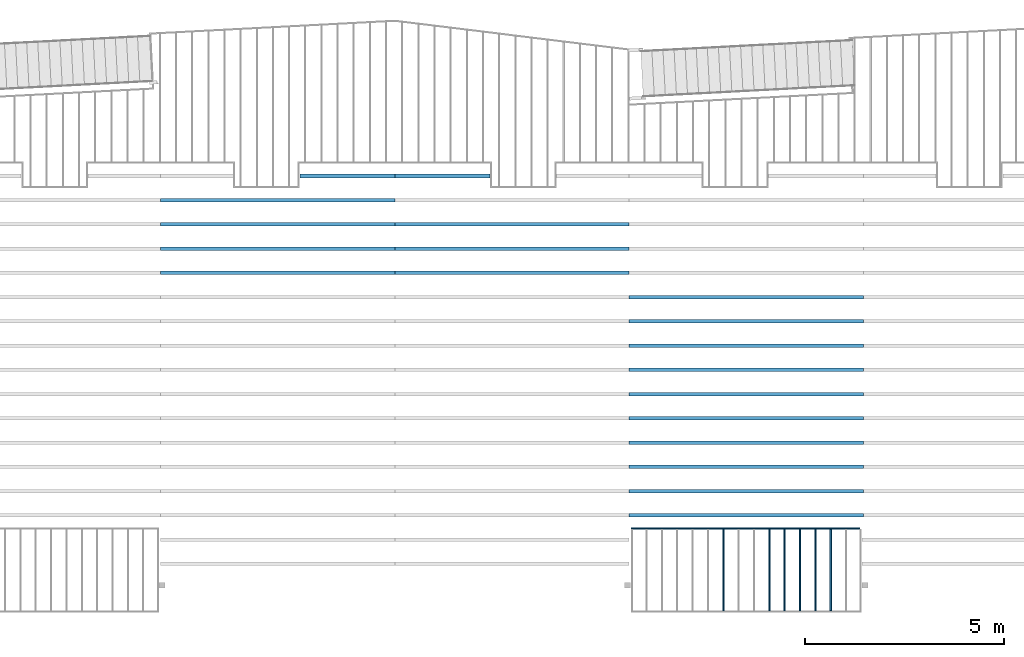
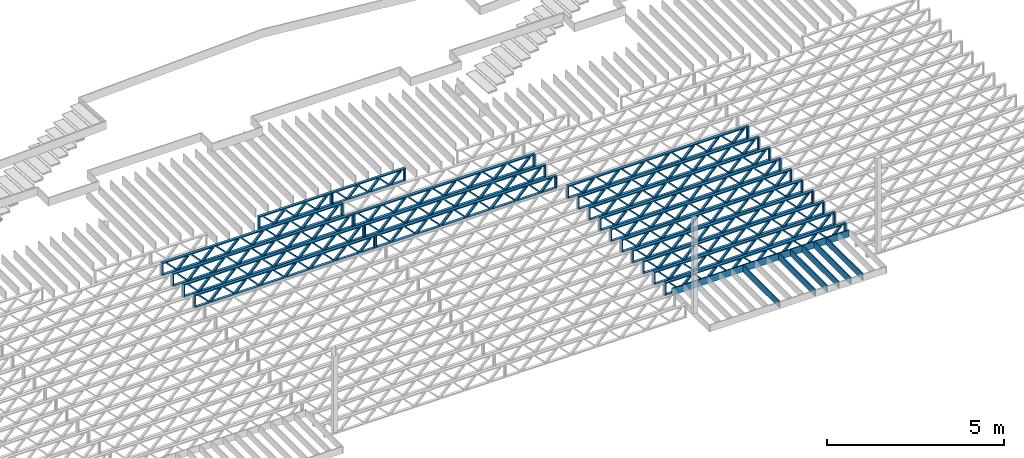
# One storey, part 7 of 23: 26 beams, 4 elements without a shape of their own.
"""IFC4 building model written with IfcOpenShell, lengths in feet."""

from ifc_helpers import new_model, entity, si_unit, converted_unit, derived_unit, direction, frame, frame_2d, origin, origin_2d_with_axis, place, context, subcontext, project, spatial, rectangle, extrude, source, transform, mapped, material, material_profile, profile_set, profile_usage, type_object, type_shapes, element, aggregate, save


model = new_model("IFC4")

# Units and contexts
model_context = context("Model", 3, precision=0.0001, world=origin(), true_north=direction((6.12303176911189e-17, 1.0)))
body_context = subcontext(model_context, "Body", "Model", "MODEL_VIEW")
ifc_project = project(units=[converted_unit("LENGTHUNIT", "FOOT", entity("IfcRatioMeasure", 0.3048), si_unit("LENGTHUNIT", "METRE"), dimensions=[1, 0, 0, 0, 0, 0, 0]), converted_unit("AREAUNIT", "SQUARE FOOT", entity("IfcRatioMeasure", 0.09290304), si_unit("AREAUNIT", "SQUARE_METRE"), dimensions=[2, 0, 0, 0, 0, 0, 0]), converted_unit("VOLUMEUNIT", "CUBIC FOOT", entity("IfcRatioMeasure", 0.028316846592), si_unit("VOLUMEUNIT", "CUBIC_METRE"), dimensions=[3, 0, 0, 0, 0, 0, 0]), converted_unit("PLANEANGLEUNIT", "DEGREE", entity("IfcRatioMeasure", 0.0174532925199433), si_unit("PLANEANGLEUNIT", "RADIAN"), dimensions=[0, 0, 0, 0, 0, 0, 0]), si_unit("MASSUNIT", "GRAM", prefix="KILO"), derived_unit("MASSDENSITYUNIT", [(si_unit("MASSUNIT", "GRAM", prefix="KILO"), 1), (si_unit("LENGTHUNIT", "METRE"), -3)]), derived_unit("MOMENTOFINERTIAUNIT", [(si_unit("LENGTHUNIT", "METRE"), 4)]), si_unit("TIMEUNIT", "SECOND"), si_unit("FREQUENCYUNIT", "HERTZ"), si_unit("THERMODYNAMICTEMPERATUREUNIT", "DEGREE_CELSIUS"), derived_unit("THERMALTRANSMITTANCEUNIT", [(si_unit("MASSUNIT", "GRAM", prefix="KILO"), 1), (si_unit("THERMODYNAMICTEMPERATUREUNIT", "KELVIN"), -1), (si_unit("TIMEUNIT", "SECOND"), -3)]), derived_unit("VOLUMETRICFLOWRATEUNIT", [(si_unit("LENGTHUNIT", "METRE"), 3), (si_unit("TIMEUNIT", "SECOND"), -1)]), si_unit("ELECTRICCURRENTUNIT", "AMPERE"), si_unit("ELECTRICVOLTAGEUNIT", "VOLT"), si_unit("POWERUNIT", "WATT"), si_unit("FORCEUNIT", "NEWTON"), si_unit("ILLUMINANCEUNIT", "LUX"), si_unit("LUMINOUSFLUXUNIT", "LUMEN"), si_unit("LUMINOUSINTENSITYUNIT", "CANDELA"), derived_unit("USERDEFINED", [(si_unit("MASSUNIT", "GRAM", prefix="KILO"), -1), (si_unit("LENGTHUNIT", "METRE"), -2), (si_unit("TIMEUNIT", "SECOND"), 3), (si_unit("LUMINOUSFLUXUNIT", "LUMEN"), 1)]), derived_unit("LINEARVELOCITYUNIT", [(si_unit("LENGTHUNIT", "METRE"), 1), (si_unit("TIMEUNIT", "SECOND"), -1)]), si_unit("PRESSUREUNIT", "PASCAL"), derived_unit("USERDEFINED", [(si_unit("LENGTHUNIT", "METRE"), -2), (si_unit("MASSUNIT", "GRAM", prefix="KILO"), 1), (si_unit("TIMEUNIT", "SECOND"), -2)]), derived_unit("LINEARFORCEUNIT", [(si_unit("MASSUNIT", "GRAM", prefix="KILO"), 1), (si_unit("LENGTHUNIT", "METRE"), 1), (si_unit("TIMEUNIT", "SECOND"), -2), (si_unit("LENGTHUNIT", "METRE"), -1)]), derived_unit("PLANARFORCEUNIT", [(si_unit("MASSUNIT", "GRAM", prefix="KILO"), 1), (si_unit("LENGTHUNIT", "METRE"), 1), (si_unit("TIMEUNIT", "SECOND"), -2), (si_unit("LENGTHUNIT", "METRE"), -2)])], contexts=[model_context])

# Site, building, storey
site_placement = place(None, origin())
site = spatial("IfcSite", under=ifc_project, at=site_placement, CompositionType="ELEMENT")
building_placement = place(site_placement, origin())
building = spatial("IfcBuilding", under=site, at=building_placement, CompositionType="ELEMENT")
storey_placement = place(building_placement, frame((0.0, 0.0, 10.8020833333333)))
storey = spatial("IfcBuildingStorey", under=building, at=storey_placement, Name="2ND FLOOR", CompositionType="ELEMENT", Elevation=10.8020833333333)

# Assembly, beams
assembly_1_placement = place(storey_placement, origin())
assembly_1 = element("IfcElementAssembly", 1, at=assembly_1_placement, inside=storey, Name="Structural Beam System:Structural Framing System", ObjectType="Structural Beam System:Structural Framing System", AssemblyPlace="NOTDEFINED", PredefinedType="BEAM_GRID")
ifc_material_1 = material(Category="Materials")
ifc_material_profile_1 = material_profile(ifc_material_1, rectangle(XDim=0.770833333333333, YDim=0.124999999999994, at=frame_2d((-5.55111512312578e-17, 0.0), x_axis=(1.0, 0.0))))
ifc_profile_set_1 = profile_set([ifc_material_profile_1])
ifc_profile_usage_1 = profile_usage(ifc_profile_set_1, cardinal=8)
beam_type_1 = type_object("IfcBeamType", PredefinedType="BEAM", material=ifc_profile_set_1)
shared_shape_1 = source(origin(), body_context, "Body", "SweptSolid", [
    extrude(rectangle(XDim=0.770833333333333, YDim=0.124999999999994, at=frame_2d((-5.55111512312578e-17, 0.0), x_axis=(1.0, 0.0))), frame((-3.35416666666737, 0.0, 0.0), z_axis=(1.0, 0.0, 0.0), x_axis=(0.0, 0.0, -1.0)), (0.0, 0.0, 1.0), 6.70833333333462),
])
type_shapes(beam_type_1, [shared_shape_1])
beam_1_placement = place(assembly_1_placement, frame((-167.102006703188, 925.341101549316, -0.645833333333471), z_axis=(0.0, 0.0, 1.0), x_axis=(0.0, 1.0, 0.0)))
beam_1 = element("IfcBeam", 2, at=beam_1_placement, type_object=beam_type_1, material=ifc_profile_usage_1, PredefinedType="BEAM", context=body_context, shape_type="MappedRepresentation", body=[
    mapped(shared_shape_1, transform((0.0, 0.0, 0.0), scale=1.0)),
])
ifc_profile_usage_2 = profile_usage(ifc_profile_set_1, cardinal=8)
beam_2_placement = place(assembly_1_placement, frame((-168.368890383746, 925.341101549316, -0.645833333333471), z_axis=(0.0, 0.0, 1.0), x_axis=(0.0, 1.0, 0.0)))
beam_2 = element("IfcBeam", 3, at=beam_2_placement, type_object=beam_type_1, material=ifc_profile_usage_2, PredefinedType="BEAM", context=body_context, shape_type="MappedRepresentation", body=[
    mapped(shared_shape_1, transform((0.0, 0.0, 0.0), scale=1.0)),
])
ifc_profile_usage_3 = profile_usage(ifc_profile_set_1, cardinal=8)
beam_3_placement = place(assembly_1_placement, frame((-169.635774064305, 925.341101549317, -0.645833333333471), z_axis=(0.0, 0.0, 1.0), x_axis=(0.0, 1.0, 0.0)))
beam_3 = element("IfcBeam", 4, at=beam_3_placement, type_object=beam_type_1, material=ifc_profile_usage_3, PredefinedType="BEAM", context=body_context, shape_type="MappedRepresentation", body=[
    mapped(shared_shape_1, transform((0.0, 0.0, 0.0), scale=1.0)),
])
ifc_profile_usage_4 = profile_usage(ifc_profile_set_1, cardinal=8)
beam_4_placement = place(assembly_1_placement, frame((-170.902657744863, 925.341101549317, -0.645833333333471), z_axis=(0.0, 0.0, 1.0), x_axis=(0.0, 1.0, 0.0)))
beam_4 = element("IfcBeam", 5, at=beam_4_placement, type_object=beam_type_1, material=ifc_profile_usage_4, PredefinedType="BEAM", context=body_context, shape_type="MappedRepresentation", body=[
    mapped(shared_shape_1, transform((0.0, 0.0, 0.0), scale=1.0)),
])
ifc_profile_usage_5 = profile_usage(ifc_profile_set_1, cardinal=8)
beam_5_placement = place(assembly_1_placement, frame((-172.169541425421, 925.341101549317, -0.645833333333471), z_axis=(0.0, 0.0, 1.0), x_axis=(0.0, 1.0, 0.0)))
beam_5 = element("IfcBeam", 6, at=beam_5_placement, type_object=beam_type_1, material=ifc_profile_usage_5, PredefinedType="BEAM", context=body_context, shape_type="MappedRepresentation", body=[
    mapped(shared_shape_1, transform((0.0, 0.0, 0.0), scale=1.0)),
])
ifc_profile_usage_6 = profile_usage(ifc_profile_set_1, cardinal=8)
beam_6_placement = place(assembly_1_placement, frame((-175.970192467096, 925.341101549318, -0.645833333333471), z_axis=(0.0, 0.0, 1.0), x_axis=(0.0, 1.0, 0.0)))
beam_6 = element("IfcBeam", 7, at=beam_6_placement, type_object=beam_type_1, material=ifc_profile_usage_6, PredefinedType="BEAM", context=body_context, shape_type="MappedRepresentation", body=[
    mapped(shared_shape_1, transform((0.0, 0.0, 0.0), scale=1.0)),
])
aggregate(assembly_1, [beam_1, beam_2, beam_3, beam_4, beam_5, beam_6])

assembly_2_placement = place(storey_placement, origin())
assembly_2 = element("IfcElementAssembly", 8, at=assembly_2_placement, inside=storey, Name="Structural Beam System:Structural Framing System", ObjectType="Structural Beam System:Structural Framing System", AssemblyPlace="NOTDEFINED", PredefinedType="BEAM_GRID")
ifc_material_2 = material(Name="WOOD TRUSS", Category="Materials")
ifc_material_profile_2 = material_profile(ifc_material_2, rectangle(XDim=1.73473973950632, YDim=0.125, at=frame_2d((-1.11022302462516e-16, 8.32667268468867e-17), x_axis=(1.0, 0.0))))
ifc_material_profile_3 = material_profile(ifc_material_2, rectangle(XDim=1.73473973950633, YDim=0.125, at=frame_2d((-1.11022302462516e-16, 8.32667268468867e-17), x_axis=(1.0, 0.0))))
ifc_material_profile_4 = material_profile(ifc_material_2, rectangle(XDim=1.73473973950632, YDim=0.125, at=frame_2d((-5.55111512312578e-17, 1.38777878078145e-16), x_axis=(1.0, 0.0))))
ifc_material_profile_5 = material_profile(ifc_material_2, rectangle(XDim=1.73473973950633, YDim=0.125, at=frame_2d((-1.11022302462516e-16, 8.32667268468867e-17), x_axis=(1.0, 0.0))))
ifc_material_profile_6 = material_profile(ifc_material_2, rectangle(XDim=1.73473973950632, YDim=0.125, at=frame_2d((-1.11022302462516e-16, 8.32667268468867e-17), x_axis=(1.0, 0.0))))
ifc_material_profile_7 = material_profile(ifc_material_2, rectangle(XDim=1.73473973950633, YDim=0.125, at=frame_2d((-2.77555756156289e-16, 3.05311331771918e-16), x_axis=(1.0, 0.0))))
ifc_material_profile_8 = material_profile(ifc_material_2, rectangle(XDim=1.73473973950632, YDim=0.124999999999999, at=frame_2d((-3.88578058618805e-16, -2.4980018054066e-16), x_axis=(1.0, 0.0))))
ifc_material_profile_9 = material_profile(ifc_material_2, rectangle(XDim=1.73473973950633, YDim=0.125, at=frame_2d((2.77555756156289e-16, -3.05311331771918e-16), x_axis=(1.0, 0.0))))
ifc_material_profile_10 = material_profile(ifc_material_2, rectangle(XDim=1.73473973950632, YDim=0.124999999999999, at=frame_2d((-1.11022302462516e-16, 8.32667268468867e-17), x_axis=(1.0, 0.0))))
ifc_material_profile_11 = material_profile(ifc_material_2, rectangle(XDim=1.73473973950633, YDim=0.125, at=origin_2d_with_axis()))
ifc_material_profile_12 = material_profile(ifc_material_2, rectangle(XDim=0.124999999999982, YDim=0.291666666666668, at=origin_2d_with_axis()))
ifc_material_profile_13 = material_profile(ifc_material_2, rectangle(XDim=0.124999999999932, YDim=0.291666666666664, at=origin_2d_with_axis()))
ifc_material_profile_14 = material_profile(ifc_material_2, rectangle(XDim=1.25000000000002, YDim=0.29166666666667, at=origin_2d_with_axis()))
ifc_material_profile_15 = material_profile(ifc_material_2, rectangle(XDim=1.25000000000004, YDim=0.291666666666667, at=origin_2d_with_axis()))
ifc_profile_set_2 = profile_set([ifc_material_profile_2, ifc_material_profile_3, ifc_material_profile_4, ifc_material_profile_5, ifc_material_profile_6, ifc_material_profile_7, ifc_material_profile_8, ifc_material_profile_9, ifc_material_profile_10, ifc_material_profile_11, ifc_material_profile_12, ifc_material_profile_13, ifc_material_profile_14, ifc_material_profile_15])
ifc_profile_usage_7 = profile_usage(ifc_profile_set_2, cardinal=8)
beam_type_2 = type_object("IfcBeamType", PredefinedType="BEAM", material=ifc_profile_set_2)
shared_shape_2 = source(origin(), body_context, "Body", "SweptSolid", [
    extrude(rectangle(XDim=1.73473973950632, YDim=0.124999999999999, at=frame_2d((5.55111512312578e-16, 7.21644966006352e-16), x_axis=(1.0, 0.0))), frame((5.95847627016997, -0.145833333333334, 0.0), z_axis=(0.0, 1.0, 0.0), x_axis=(0.693383046997606, 0.0, 0.720569184836762)), (0.0, 0.0, 1.0), 0.291666666666667),
    extrude(rectangle(XDim=1.73473973950633, YDim=0.125, at=origin_2d_with_axis()), frame((4.7081903964967, -0.145833333333334, 0.0), z_axis=(0.0, 1.0, 0.0), x_axis=(0.69338304699761, 0.0, -0.720569184836758)), (0.0, 0.0, 1.0), 0.291666666666666),
    extrude(rectangle(XDim=1.73473973950632, YDim=0.125, at=frame_2d((2.22044604925031e-16, 3.88578058618805e-16), x_axis=(1.0, 0.0))), frame((3.29180960350347, -0.145833333333334, 0.0), z_axis=(0.0, 1.0, 0.0), x_axis=(0.693383046997606, 0.0, 0.720569184836762)), (0.0, 0.0, 1.0), 0.291666666666667),
    extrude(rectangle(XDim=1.73473973950633, YDim=0.125, at=frame_2d((1.11022302462516e-16, -8.32667268468867e-17), x_axis=(1.0, 0.0))), frame((2.0415237298302, -0.145833333333334, 0.0), z_axis=(0.0, 1.0, 0.0), x_axis=(0.69338304699761, 0.0, -0.720569184836758)), (0.0, 0.0, 1.0), 0.291666666666667),
    extrude(rectangle(XDim=1.73473973950632, YDim=0.125, at=frame_2d((-5.55111512312578e-17, 1.38777878078145e-16), x_axis=(1.0, 0.0))), frame((0.625142936836964, -0.145833333333334, 0.0), z_axis=(0.0, 1.0, 0.0), x_axis=(0.693383046997606, 0.0, 0.720569184836762)), (0.0, 0.0, 1.0), 0.291666666666667),
    extrude(rectangle(XDim=1.73473973950633, YDim=0.125, at=frame_2d((-1.11022302462516e-16, 8.32667268468867e-17), x_axis=(1.0, 0.0))), frame((-0.625142936836306, -0.145833333333334, 0.0), z_axis=(0.0, 1.0, 0.0), x_axis=(0.69338304699761, 0.0, -0.720569184836758)), (0.0, 0.0, 1.0), 0.291666666666667),
    extrude(rectangle(XDim=1.73473973950632, YDim=0.125, at=frame_2d((-1.11022302462516e-16, 8.32667268468867e-17), x_axis=(1.0, 0.0))), frame((-2.04152372982954, -0.145833333333334, 0.0), z_axis=(0.0, 1.0, 0.0), x_axis=(0.693383046997606, 0.0, 0.720569184836762)), (0.0, 0.0, 1.0), 0.291666666666667),
    extrude(rectangle(XDim=1.73473973950633, YDim=0.125, at=origin_2d_with_axis()), frame((-3.29180960350281, -0.145833333333334, 0.0), z_axis=(0.0, 1.0, 0.0), x_axis=(0.69338304699761, 0.0, -0.720569184836758)), (0.0, 0.0, 1.0), 0.291666666666667),
    extrude(rectangle(XDim=1.73473973950632, YDim=0.124999999999999, at=frame_2d((-1.11022302462516e-16, 8.32667268468867e-17), x_axis=(1.0, 0.0))), frame((-4.70819039649604, -0.145833333333334, 0.0), z_axis=(0.0, 1.0, 0.0), x_axis=(0.693383046997606, 0.0, 0.720569184836762)), (0.0, 0.0, 1.0), 0.291666666666667),
    extrude(rectangle(XDim=1.73473973950633, YDim=0.125, at=frame_2d((-5.55111512312578e-16, 6.38378239159465e-16), x_axis=(1.0, 0.0))), frame((-5.95847627016931, -0.145833333333334, 0.0), z_axis=(0.0, 1.0, 0.0), x_axis=(0.69338304699761, 0.0, -0.720569184836758)), (0.0, 0.0, 1.0), 0.291666666666666),
    extrude(rectangle(XDim=1.73473973950632, YDim=0.125, at=frame_2d((-7.21644966006352e-16, -5.82867087928207e-16), x_axis=(1.0, 0.0))), frame((8.62514293683647, -0.145833333333334, 0.0), z_axis=(0.0, 1.0, 0.0), x_axis=(0.693383046997607, 0.0, 0.720569184836761)), (0.0, 0.0, 1.0), 0.291666666666667),
    extrude(rectangle(XDim=1.73473973950633, YDim=0.125, at=origin_2d_with_axis()), frame((7.3748570631632, -0.145833333333334, 0.0), z_axis=(0.0, 1.0, 0.0), x_axis=(0.69338304699761, 0.0, -0.720569184836758)), (0.0, 0.0, 1.0), 0.291666666666666),
    extrude(rectangle(XDim=1.73473973950632, YDim=0.124999999999999, at=frame_2d((-1.11022302462516e-16, 8.32667268468867e-17), x_axis=(1.0, 0.0))), frame((-7.37485706316255, -0.145833333333334, 0.0), z_axis=(0.0, 1.0, 0.0), x_axis=(0.693383046997606, 0.0, 0.720569184836762)), (0.0, 0.0, 1.0), 0.291666666666667),
    extrude(rectangle(XDim=1.73473973950633, YDim=0.125, at=origin_2d_with_axis()), frame((-8.62514293683582, -0.145833333333334, 0.0), z_axis=(0.0, 1.0, 0.0), x_axis=(0.69338304699761, 0.0, -0.720569184836758)), (0.0, 0.0, 1.0), 0.291666666666666),
    extrude(rectangle(XDim=0.124999999999982, YDim=0.291666666666668, at=origin_2d_with_axis()), frame((-9.66666666666609, 0.0, 0.687500000000054), z_axis=(1.0, 0.0, 0.0), x_axis=(0.0, 0.0, -1.0)), (0.0, 0.0, 1.0), 19.3333333333322),
    extrude(rectangle(XDim=0.124999999999932, YDim=0.291666666666664, at=origin_2d_with_axis()), frame((-9.66666666666588, 0.0, -0.687499999999984), z_axis=(1.0, 0.0, 0.0), x_axis=(0.0, 0.0, -1.0)), (0.0, 0.0, 1.0), 19.333333333332),
    extrude(rectangle(XDim=1.25000000000002, YDim=0.29166666666667, at=origin_2d_with_axis()), frame((9.54166666666607, 0.0, 0.0), z_axis=(1.0, 0.0, 0.0), x_axis=(0.0, 0.0, -1.0)), (0.0, 0.0, 1.0), 0.12500000000002),
    extrude(rectangle(XDim=1.25000000000004, YDim=0.291666666666667, at=origin_2d_with_axis()), frame((-9.66666666666609, 0.0, 0.0), z_axis=(1.0, 0.0, 0.0), x_axis=(0.0, 0.0, -1.0)), (0.0, 0.0, 1.0), 0.125000000000023),
])
type_shapes(beam_type_2, [shared_shape_2])
beam_7_placement = place(assembly_2_placement, frame((-174.071493818896, 947.861934882651, -0.947916666666657), z_axis=(0.0, 0.0, 1.0), x_axis=(-1.0, 0.0, 0.0)))
beam_7 = element("IfcBeam", 9, at=beam_7_placement, type_object=beam_type_2, material=ifc_profile_usage_7, PredefinedType="BEAM", context=body_context, shape_type="MappedRepresentation", body=[
    mapped(shared_shape_2, transform((0.0, 0.0, 0.0), scale=1.0)),
])
ifc_profile_usage_8 = profile_usage(ifc_profile_set_2, cardinal=8)
beam_8_placement = place(assembly_2_placement, frame((-174.071493818896, 945.861934882651, -0.947916666666657), z_axis=(0.0, 0.0, 1.0), x_axis=(-1.0, 0.0, 0.0)))
beam_8 = element("IfcBeam", 10, at=beam_8_placement, type_object=beam_type_2, material=ifc_profile_usage_8, PredefinedType="BEAM", context=body_context, shape_type="MappedRepresentation", body=[
    mapped(shared_shape_2, transform((0.0, 0.0, 0.0), scale=1.0)),
])
ifc_profile_usage_9 = profile_usage(ifc_profile_set_2, cardinal=8)
beam_9_placement = place(assembly_2_placement, frame((-174.071493818896, 943.861934882651, -0.947916666666657), z_axis=(0.0, 0.0, 1.0), x_axis=(-1.0, 0.0, 0.0)))
beam_9 = element("IfcBeam", 11, at=beam_9_placement, type_object=beam_type_2, material=ifc_profile_usage_9, PredefinedType="BEAM", context=body_context, shape_type="MappedRepresentation", body=[
    mapped(shared_shape_2, transform((0.0, 0.0, 0.0), scale=1.0)),
])
ifc_profile_usage_10 = profile_usage(ifc_profile_set_2, cardinal=8)
beam_10_placement = place(assembly_2_placement, frame((-174.071493818896, 941.861934882651, -0.947916666666657), z_axis=(0.0, 0.0, 1.0), x_axis=(-1.0, 0.0, 0.0)))
beam_10 = element("IfcBeam", 12, at=beam_10_placement, type_object=beam_type_2, material=ifc_profile_usage_10, PredefinedType="BEAM", context=body_context, shape_type="MappedRepresentation", body=[
    mapped(shared_shape_2, transform((0.0, 0.0, 0.0), scale=1.0)),
])
ifc_profile_usage_11 = profile_usage(ifc_profile_set_2, cardinal=8)
beam_11_placement = place(assembly_2_placement, frame((-174.071493818896, 939.861934882651, -0.947916666666657), z_axis=(0.0, 0.0, 1.0), x_axis=(-1.0, 0.0, 0.0)))
beam_11 = element("IfcBeam", 13, at=beam_11_placement, type_object=beam_type_2, material=ifc_profile_usage_11, PredefinedType="BEAM", context=body_context, shape_type="MappedRepresentation", body=[
    mapped(shared_shape_2, transform((0.0, 0.0, 0.0), scale=1.0)),
])
ifc_profile_usage_12 = profile_usage(ifc_profile_set_2, cardinal=8)
beam_12_placement = place(assembly_2_placement, frame((-174.071493818896, 937.861934882651, -0.947916666666657), z_axis=(0.0, 0.0, 1.0), x_axis=(-1.0, 0.0, 0.0)))
beam_12 = element("IfcBeam", 14, at=beam_12_placement, type_object=beam_type_2, material=ifc_profile_usage_12, PredefinedType="BEAM", context=body_context, shape_type="MappedRepresentation", body=[
    mapped(shared_shape_2, transform((0.0, 0.0, 0.0), scale=1.0)),
])
ifc_profile_usage_13 = profile_usage(ifc_profile_set_2, cardinal=8)
beam_13_placement = place(assembly_2_placement, frame((-174.071493818896, 935.861934882651, -0.947916666666657), z_axis=(0.0, 0.0, 1.0), x_axis=(-1.0, 0.0, 0.0)))
beam_13 = element("IfcBeam", 15, at=beam_13_placement, type_object=beam_type_2, material=ifc_profile_usage_13, PredefinedType="BEAM", context=body_context, shape_type="MappedRepresentation", body=[
    mapped(shared_shape_2, transform((0.0, 0.0, 0.0), scale=1.0)),
])
ifc_profile_usage_14 = profile_usage(ifc_profile_set_2, cardinal=8)
beam_14_placement = place(assembly_2_placement, frame((-174.071493818896, 933.861934882651, -0.947916666666657), z_axis=(0.0, 0.0, 1.0), x_axis=(-1.0, 0.0, 0.0)))
beam_14 = element("IfcBeam", 16, at=beam_14_placement, type_object=beam_type_2, material=ifc_profile_usage_14, PredefinedType="BEAM", context=body_context, shape_type="MappedRepresentation", body=[
    mapped(shared_shape_2, transform((0.0, 0.0, 0.0), scale=1.0)),
])
ifc_profile_usage_15 = profile_usage(ifc_profile_set_2, cardinal=8)
beam_15_placement = place(assembly_2_placement, frame((-174.071493818896, 931.861934882651, -0.947916666666657), z_axis=(0.0, 0.0, 1.0), x_axis=(-1.0, 0.0, 0.0)))
beam_15 = element("IfcBeam", 17, at=beam_15_placement, type_object=beam_type_2, material=ifc_profile_usage_15, PredefinedType="BEAM", context=body_context, shape_type="MappedRepresentation", body=[
    mapped(shared_shape_2, transform((0.0, 0.0, 0.0), scale=1.0)),
])
ifc_profile_usage_16 = profile_usage(ifc_profile_set_2, cardinal=8)
beam_16_placement = place(assembly_2_placement, frame((-174.071493818896, 929.861934882651, -0.947916666666657), z_axis=(0.0, 0.0, 1.0), x_axis=(-1.0, 0.0, 0.0)))
beam_16 = element("IfcBeam", 18, at=beam_16_placement, type_object=beam_type_2, material=ifc_profile_usage_16, PredefinedType="BEAM", context=body_context, shape_type="MappedRepresentation", body=[
    mapped(shared_shape_2, transform((0.0, 0.0, 0.0), scale=1.0)),
])
aggregate(assembly_2, [beam_7, beam_8, beam_9, beam_10, beam_11, beam_12, beam_13, beam_14, beam_15, beam_16])

assembly_3_placement = place(storey_placement, origin())
assembly_3 = element("IfcElementAssembly", 19, at=assembly_3_placement, inside=storey, Name="Structural Beam System:Structural Framing System", ObjectType="Structural Beam System:Structural Framing System", AssemblyPlace="NOTDEFINED", PredefinedType="BEAM_GRID")
ifc_profile_usage_17 = profile_usage(ifc_profile_set_2, cardinal=8)
beam_17_placement = place(assembly_3_placement, frame((-193.404827152229, 953.861934882651, -0.947916666666881)))
beam_17 = element("IfcBeam", 20, at=beam_17_placement, type_object=beam_type_2, material=ifc_profile_usage_17, PredefinedType="BEAM", context=body_context, shape_type="MappedRepresentation", body=[
    mapped(shared_shape_2, transform((0.0, 0.0, 0.0), scale=1.0)),
])
ifc_profile_usage_18 = profile_usage(ifc_profile_set_2, cardinal=8)
beam_18_placement = place(assembly_3_placement, frame((-193.404827152229, 951.861934882651, -0.947916666666881)))
beam_18 = element("IfcBeam", 21, at=beam_18_placement, type_object=beam_type_2, material=ifc_profile_usage_18, PredefinedType="BEAM", context=body_context, shape_type="MappedRepresentation", body=[
    mapped(shared_shape_2, transform((0.0, 0.0, 0.0), scale=1.0)),
])
ifc_profile_usage_19 = profile_usage(ifc_profile_set_2, cardinal=8)
beam_19_placement = place(assembly_3_placement, frame((-193.404827152229, 949.861934882651, -0.947916666666881)))
beam_19 = element("IfcBeam", 22, at=beam_19_placement, type_object=beam_type_2, material=ifc_profile_usage_19, PredefinedType="BEAM", context=body_context, shape_type="MappedRepresentation", body=[
    mapped(shared_shape_2, transform((0.0, 0.0, 0.0), scale=1.0)),
])

assembly_4_placement = place(storey_placement, origin())
assembly_4 = element("IfcElementAssembly", 23, at=assembly_4_placement, inside=storey, Name="Structural Beam System:Structural Framing System", ObjectType="Structural Beam System:Structural Framing System", AssemblyPlace="NOTDEFINED", PredefinedType="BEAM_GRID")
ifc_profile_usage_20 = profile_usage(ifc_profile_set_2, cardinal=8)
beam_20_placement = place(assembly_4_placement, frame((-212.738160485495, 955.861934882651, -0.947916666666881), z_axis=(0.0, 0.0, 1.0), x_axis=(-1.0, 0.0, 0.0)))
beam_20 = element("IfcBeam", 24, at=beam_20_placement, type_object=beam_type_2, material=ifc_profile_usage_20, PredefinedType="BEAM", context=body_context, shape_type="MappedRepresentation", body=[
    mapped(shared_shape_2, transform((0.0, 0.0, 0.0), scale=1.0)),
])
ifc_profile_usage_21 = profile_usage(ifc_profile_set_2, cardinal=8)
beam_21_placement = place(assembly_4_placement, frame((-212.738160485495, 953.861934882651, -0.947916666666881), z_axis=(0.0, 0.0, 1.0), x_axis=(-1.0, 0.0, 0.0)))
beam_21 = element("IfcBeam", 25, at=beam_21_placement, type_object=beam_type_2, material=ifc_profile_usage_21, PredefinedType="BEAM", context=body_context, shape_type="MappedRepresentation", body=[
    mapped(shared_shape_2, transform((0.0, 0.0, 0.0), scale=1.0)),
])
ifc_profile_usage_22 = profile_usage(ifc_profile_set_2, cardinal=8)
beam_22_placement = place(assembly_4_placement, frame((-212.738160485495, 951.861934882651, -0.947916666666881), z_axis=(0.0, 0.0, 1.0), x_axis=(-1.0, 0.0, 0.0)))
beam_22 = element("IfcBeam", 26, at=beam_22_placement, type_object=beam_type_2, material=ifc_profile_usage_22, PredefinedType="BEAM", context=body_context, shape_type="MappedRepresentation", body=[
    mapped(shared_shape_2, transform((0.0, 0.0, 0.0), scale=1.0)),
])
ifc_profile_usage_23 = profile_usage(ifc_profile_set_2, cardinal=8)
beam_23_placement = place(assembly_4_placement, frame((-212.738160485495, 949.861934882651, -0.947916666666881), z_axis=(0.0, 0.0, 1.0), x_axis=(-1.0, 0.0, 0.0)))
beam_23 = element("IfcBeam", 27, at=beam_23_placement, type_object=beam_type_2, material=ifc_profile_usage_23, PredefinedType="BEAM", context=body_context, shape_type="MappedRepresentation", body=[
    mapped(shared_shape_2, transform((0.0, 0.0, 0.0), scale=1.0)),
])

# Beam
ifc_profile_usage_24 = profile_usage(ifc_profile_set_2, cardinal=8)
beam_type_3 = type_object("IfcBeamType", PredefinedType="BEAM", material=ifc_profile_set_2)
shared_shape_3 = source(origin(), body_context, "Body", "SweptSolid", [
    extrude(rectangle(XDim=1.73473973950632, YDim=0.125, at=frame_2d((-5.55111512312578e-17, 1.38777878078145e-16), x_axis=(1.0, 0.0))), frame((0.625142936836963, -0.145833333333334, 0.0), z_axis=(0.0, 1.0, 0.0), x_axis=(0.693383046997606, 0.0, 0.720569184836762)), (0.0, 0.0, 1.0), 0.291666666666667),
    extrude(rectangle(XDim=1.73473973950633, YDim=0.125, at=frame_2d((-1.11022302462516e-16, 8.32667268468867e-17), x_axis=(1.0, 0.0))), frame((-0.625142936836308, -0.145833333333334, 0.0), z_axis=(0.0, 1.0, 0.0), x_axis=(0.69338304699761, 0.0, -0.720569184836758)), (0.0, 0.0, 1.0), 0.291666666666667),
    extrude(rectangle(XDim=1.73473973950632, YDim=0.125, at=frame_2d((-1.11022302462516e-16, 8.32667268468867e-17), x_axis=(1.0, 0.0))), frame((2.87514285312432, -0.145833333333334, 0.0), z_axis=(0.0, 1.0, 0.0), x_axis=(0.693383046997606, 0.0, 0.720569184836762)), (0.0, 0.0, 1.0), 0.291666666666667),
    extrude(rectangle(XDim=1.73473973950633, YDim=0.125, at=frame_2d((-1.11022302462516e-16, 8.32667268468867e-17), x_axis=(1.0, 0.0))), frame((1.62485697945105, -0.145833333333334, 0.0), z_axis=(0.0, 1.0, 0.0), x_axis=(0.69338304699761, 0.0, -0.720569184836758)), (0.0, 0.0, 1.0), 0.291666666666667),
    extrude(rectangle(XDim=1.73473973950632, YDim=0.125, at=frame_2d((-1.11022302462516e-16, 8.32667268468867e-17), x_axis=(1.0, 0.0))), frame((-1.62485697945039, -0.145833333333334, 0.0), z_axis=(0.0, 1.0, 0.0), x_axis=(0.693383046997606, 0.0, 0.720569184836762)), (0.0, 0.0, 1.0), 0.291666666666667),
    extrude(rectangle(XDim=1.73473973950633, YDim=0.125, at=origin_2d_with_axis()), frame((-2.87514285312366, -0.145833333333334, 0.0), z_axis=(0.0, 1.0, 0.0), x_axis=(0.69338304699761, 0.0, -0.720569184836758)), (0.0, 0.0, 1.0), 0.291666666666667),
    extrude(rectangle(XDim=0.124999999999982, YDim=0.291666666666668, at=origin_2d_with_axis()), frame((-3.91666658295394, 0.0, 0.687500000000054), z_axis=(1.0, 0.0, 0.0), x_axis=(0.0, 0.0, -1.0)), (0.0, 0.0, 1.0), 7.83333316590787),
    extrude(rectangle(XDim=0.124999999999932, YDim=0.291666666666664, at=origin_2d_with_axis()), frame((-3.91666658295372, 0.0, -0.687499999999984), z_axis=(1.0, 0.0, 0.0), x_axis=(0.0, 0.0, -1.0)), (0.0, 0.0, 1.0), 7.83333316590766),
    extrude(rectangle(XDim=1.25000000000002, YDim=0.29166666666667, at=origin_2d_with_axis()), frame((3.79166658295392, 0.0, 0.0), z_axis=(1.0, 0.0, 0.0), x_axis=(0.0, 0.0, -1.0)), (0.0, 0.0, 1.0), 0.12500000000002),
    extrude(rectangle(XDim=1.25000000000004, YDim=0.291666666666667, at=origin_2d_with_axis()), frame((-3.91666658295394, 0.0, 0.0), z_axis=(1.0, 0.0, 0.0), x_axis=(0.0, 0.0, -1.0)), (0.0, 0.0, 1.0), 0.125000000000023),
])
type_shapes(beam_type_3, [shared_shape_3])
beam_24_placement = place(assembly_3_placement, frame((-199.154827235941, 957.861934882651, -0.947916666666881)))
beam_24 = element("IfcBeam", 28, at=beam_24_placement, type_object=beam_type_3, material=ifc_profile_usage_24, PredefinedType="BEAM", context=body_context, shape_type="MappedRepresentation", body=[
    mapped(shared_shape_3, transform((0.0, 0.0, 0.0), scale=1.0)),
])

aggregate(assembly_3, [beam_24, beam_17, beam_18, beam_19])

ifc_profile_usage_25 = profile_usage(ifc_profile_set_2, cardinal=8)
beam_25_placement = place(assembly_4_placement, frame((-206.988160401783, 957.861934882651, -0.947916666666881), z_axis=(0.0, 0.0, 1.0), x_axis=(-1.0, 0.0, 0.0)))
beam_25 = element("IfcBeam", 29, at=beam_25_placement, type_object=beam_type_3, material=ifc_profile_usage_25, PredefinedType="BEAM", context=body_context, shape_type="MappedRepresentation", body=[
    mapped(shared_shape_3, transform((0.0, 0.0, 0.0), scale=1.0)),
])

aggregate(assembly_4, [beam_25, beam_20, beam_21, beam_22, beam_23])

ifc_profile_usage_26 = profile_usage(ifc_profile_set_1, cardinal=8)
beam_type_4 = type_object("IfcBeamType", PredefinedType="BEAM", material=ifc_profile_set_1)
shared_shape_4 = source(origin(), body_context, "Body", "SweptSolid", [
    extrude(rectangle(XDim=0.770833333333333, YDim=0.124999999999994, at=frame_2d((-1.11022302462516e-16, 0.0), x_axis=(1.0, 0.0))), frame((-9.49999887751909, 0.0, 0.0), z_axis=(1.0, 0.0, 0.0), x_axis=(0.0, 0.0, -1.0)), (0.0, 0.0, 1.0), 18.8749977550382),
])
type_shapes(beam_type_4, [shared_shape_4])
beam_26_placement = place(storey_placement, frame((-174.071492696381, 928.757768215985, -0.645833333333506)))
element("IfcBeam", 30, at=beam_26_placement, inside=storey, type_object=beam_type_4, material=ifc_profile_usage_26, PredefinedType="BEAM", context=body_context, shape_type="MappedRepresentation", body=[
    mapped(shared_shape_4, transform((0.0, 0.0, 0.0), scale=1.0)),
])

save(model, "model.ifc")
